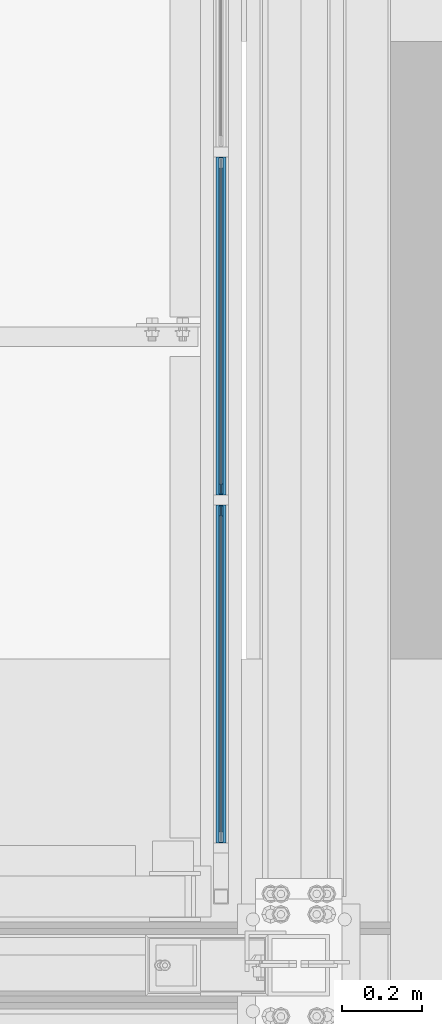
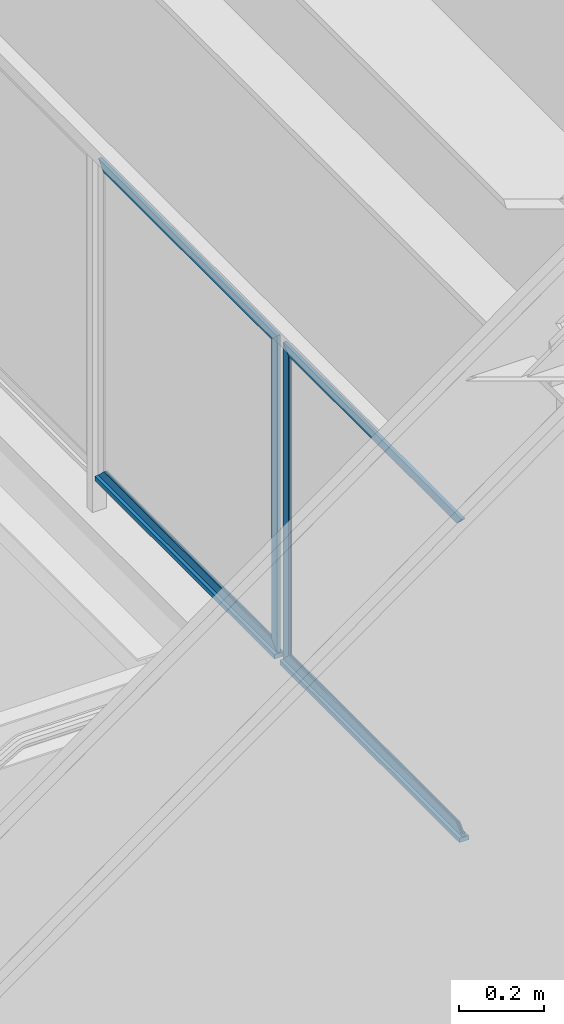
# One storey, part 924 of 1179: 6 beams, 2 members, 1 element without a shape of its own.
"""IFC2X3 building model written with IfcOpenShell, lengths in millimetres."""

from ifc_helpers import new_model, si_unit, frame, origin_with_axes, place, context, subcontext, project, spatial, faceted_brep, material, type_object, element, aggregate, save


model = new_model("IFC2X3")

# Units and contexts
model_context = context("Model", 3, precision=1e-05, world=origin_with_axes())
body_context = subcontext(model_context, "Body", "Model", "MODEL_VIEW")
ifc_project = project(units=[si_unit("LENGTHUNIT", "METRE", prefix="MILLI"), si_unit("AREAUNIT", "SQUARE_METRE"), si_unit("VOLUMEUNIT", "CUBIC_METRE"), si_unit("MASSUNIT", "GRAM", prefix="KILO"), si_unit("TIMEUNIT", "SECOND"), si_unit("PLANEANGLEUNIT", "RADIAN"), si_unit("SOLIDANGLEUNIT", "STERADIAN"), si_unit("THERMODYNAMICTEMPERATUREUNIT", "DEGREE_CELSIUS"), si_unit("LUMINOUSINTENSITYUNIT", "LUMEN")], contexts=[model_context])

# Site, building, storey
site_placement = place(None, origin_with_axes())
site = spatial("IfcSite", under=ifc_project, at=site_placement, CompositionType="ELEMENT")
building_placement = place(site_placement, origin_with_axes())
building = spatial("IfcBuilding", under=site, at=building_placement, Name="Undefined", CompositionType="ELEMENT")
storey_placement = place(building_placement, origin_with_axes())
storey = spatial("IfcBuildingStorey", under=building, at=storey_placement, Name="Undefined", CompositionType="ELEMENT", Elevation=0.0)

# Assembly, beams, members
assembly_placement = place(storey_placement, origin_with_axes())
assembly = element("IfcElementAssembly", 1, at=assembly_placement, inside=storey, Name="GUARDRAIL", AssemblyPlace="NOTDEFINED", PredefinedType="RIGID_FRAME")
ifc_material_1 = material(Name="STEEL/BUY-OUT")
beam_type = type_object("IfcBeamType", PredefinedType="NOTDEFINED")
beam_1_placement = place(assembly_placement, frame((24110.9500703529, 39183.3359575509, 2711.44999945388), z_axis=(0.0, 0.0, 1.0), x_axis=(0.0, -1.0, 0.0)))
beam_1 = element("IfcBeam", 2, at=beam_1_placement, type_object=beam_type, material=ifc_material_1, Name="U-EDGE", context=body_context, shape_type="Brep", body=[
    faceted_brep([(0.0, 1.58750000000146, -427.037571475466), (22.2249999999985, 1.58750000000146, -449.262071101228), (22.2249999999985, 4.76249999999709, -449.262071101228), (0.0, 4.76249999999709, -427.037571475466), (0.0, 7.9375, -427.037571475466), (25.4000000000015, 7.9375, -452.4375), (25.4000000000015, -1.58750000000146, -452.4375), (0.0, -1.58750000000146, -427.037571475466), (25.4000000000015, -1.58750000000146, 452.4375), (0.0, -1.58750000000146, 427.037500076054), (0.0, 1.58750000000146, 427.037500076054), (22.2249999999985, 1.58750000000146, 449.262500000033), (22.2249999999985, 4.76249999999709, 449.262500000033), (0.0, 4.76249999999709, 427.037500000033), (0.0, 7.9375, 427.037500000033), (25.4000000000015, 7.9375, 452.4375)], [[[0, 1, 2, 3, 4, 5, 6, 7]], [[7, 6, 8, 9]], [[0, 7, 9, 10]], [[1, 0, 10, 11]], [[2, 1, 11, 12]], [[3, 2, 12, 13]], [[4, 3, 13, 14]], [[5, 4, 14, 15]], [[6, 5, 15, 8]], [[14, 13, 12, 11, 10, 9, 8, 15]]]),
])
beam_2_placement = place(assembly_placement, frame((24110.9502052178, 39576.2424575509, 3138.48749945388), z_axis=(0.0, 1.0, 0.0), x_axis=(0.0, 0.0, 1.0)))
beam_2 = element("IfcBeam", 3, at=beam_2_placement, type_object=beam_type, material=ifc_material_1, Name="U-EDGE", context=body_context, shape_type="Brep", body=[
    faceted_brep([(0.0, 1.58750000000146, -392.906500000216), (22.2249999999785, 1.58750000000146, -415.131500000192), (22.2249999999603, 4.76236513509502, -415.131500000178), (-5.54791768081486e-11, 4.76236513509502, -392.906500000165), (-5.54791768081486e-11, 7.93736513509793, -392.906500000165), (25.3999999999414, 7.93736513509793, -418.306499999999), (25.3999999999969, -1.58750000000146, -418.306499999999), (0.0, -1.58750000000146, -392.906500000216), (25.3999999999969, -1.58750000000146, 418.306499999999), (0.0, -1.58750000000146, 392.90650078046), (0.0, 1.58750000000146, 392.90650078046), (22.2249999999785, 1.58750000000146, 415.131500780415), (22.2249999999603, 4.76236513509502, 415.131500780393), (-5.54791768081486e-11, 4.76236513509502, 392.90650078038), (-5.54791768081486e-11, 7.93736513509793, 392.90650078038), (25.3999999999414, 7.93736513509793, 418.306499999999)], [[[0, 1, 2, 3, 4, 5, 6, 7]], [[7, 6, 8, 9]], [[0, 7, 9, 10]], [[1, 0, 10, 11]], [[2, 1, 11, 12]], [[3, 2, 12, 13]], [[4, 3, 13, 14]], [[5, 4, 14, 15]], [[6, 5, 15, 8]], [[14, 13, 12, 11, 10, 9, 8, 15]]]),
])
beam_3_placement = place(assembly_placement, frame((24110.9502052178, 39576.2424575509, 2284.41249958167), z_axis=(0.0, 1.0, 0.0), x_axis=(0.0, 0.0, -1.0)))
beam_3 = element("IfcBeam", 4, at=beam_3_placement, type_object=beam_type, material=ifc_material_1, Name="U-EDGE", context=body_context, shape_type="Brep", body=[
    faceted_brep([(-5.45696821063757e-11, -4.76236513509502, -392.906500000157), (22.2249999999613, -4.76236513509502, -415.131500000178), (22.2249999999794, -1.58750000000146, -415.131500000192), (0.0, -1.58750000000146, -392.906500000216), (0.0, 1.58750000000146, -392.906500000216), (25.3999999999969, 1.58750000000146, -418.306499999999), (25.3999999999423, -7.93736513509793, -418.306499999999), (-5.45696821063757e-11, -7.93736513509793, -392.906500000157), (25.3999999999423, -7.93736513509793, 418.306499999999), (-5.45696821063757e-11, -7.93736513509793, 392.906500780409), (-5.45696821063757e-11, -4.76236513509502, 392.906500780409), (22.2249999999613, -4.76236513509502, 415.131500780422), (22.2249999999794, -1.58750000000146, 415.131500780437), (0.0, -1.58750000000146, 392.90650078046), (0.0, 1.58750000000146, 392.90650078046), (25.3999999999969, 1.58750000000146, 418.306499999999)], [[[0, 1, 2, 3, 4, 5, 6, 7]], [[7, 6, 8, 9]], [[0, 7, 9, 10]], [[1, 0, 10, 11]], [[2, 1, 11, 12]], [[3, 2, 12, 13]], [[4, 3, 13, 14]], [[5, 4, 14, 15]], [[6, 5, 15, 8]], [[14, 13, 12, 11, 10, 9, 8, 15]]]),
])
beam_4_placement = place(assembly_placement, frame((24110.9502052178, 38710.5257908844, 2284.41250006389), z_axis=(0.0, 1.0, 0.0), x_axis=(0.0, 0.0, -1.0)))
beam_4 = element("IfcBeam", 5, at=beam_4_placement, type_object=beam_type, material=ifc_material_1, Name="U-EDGE", context=body_context, shape_type="Brep", body=[
    faceted_brep([(-5.45696821063757e-11, -4.76236513509502, -392.906500000157), (22.2249999999613, -4.76236513509502, -415.131500000178), (22.2249999999794, -1.58750000000146, -415.131500000192), (0.0, -1.58750000000146, -392.906500000216), (0.0, 1.58750000000146, -392.906500000216), (25.3999999999969, 1.58750000000146, -418.306499999999), (25.3999999999423, -7.93736513509793, -418.306499999999), (-5.45696821063757e-11, -7.93736513509793, -392.906500000157), (25.3999999999423, -7.93736513509793, 418.306499999999), (-5.45696821063757e-11, -7.93736513509793, 392.906500780409), (-5.45696821063757e-11, -4.76236513509502, 392.906500780409), (22.2249999999613, -4.76236513509502, 415.131500780422), (22.2249999999794, -1.58750000000146, 415.131500780437), (0.0, -1.58750000000146, 392.90650078046), (0.0, 1.58750000000146, 392.90650078046), (25.3999999999969, 1.58750000000146, 418.306499999999)], [[[0, 1, 2, 3, 4, 5, 6, 7]], [[7, 6, 8, 9]], [[0, 7, 9, 10]], [[1, 0, 10, 11]], [[2, 1, 11, 12]], [[3, 2, 12, 13]], [[4, 3, 13, 14]], [[5, 4, 14, 15]], [[6, 5, 15, 8]], [[14, 13, 12, 11, 10, 9, 8, 15]]]),
])
beam_5_placement = place(assembly_placement, frame((24110.9500703529, 39103.4322916676, 2711.44999993605), z_axis=(0.0, 0.0, 1.0), x_axis=(0.0, 1.0, 0.0)))
beam_5 = element("IfcBeam", 6, at=beam_5_placement, type_object=beam_type, material=ifc_material_1, Name="U-EDGE", context=body_context, shape_type="Brep", body=[
    faceted_brep([(2.91038304567337e-11, -4.76249999999709, -427.037499923914), (22.2250000000131, -4.76249999999709, -449.2624999239), (22.2250000000131, -1.58750000000146, -449.2624999239), (0.0, -1.58750000000146, -427.037499923886), (0.0, 1.58750000000146, -427.037499923886), (25.4000000439901, 1.58750000000146, -452.437500000357), (25.4000000476099, -7.93749999539432, -452.437500000422), (2.91038304567337e-11, -7.9375, -427.037499923914), (25.4000000000647, -7.9375, 452.4375), (1.29148247651756e-10, -7.9375, 427.037500076181), (1.29148247651756e-10, -4.76249999999709, 427.037500076181), (22.2250000000645, -4.76249999999709, 449.262500076118), (22.2250000000645, -1.58750000000146, 449.262500076118), (0.0, -1.58750000000146, 427.037500076054), (0.0, 1.58750000000146, 427.037500076054), (25.4000000000647, 1.58750000000146, 452.4375)], [[[0, 1, 2, 3, 4, 5, 6, 7]], [[8, 9, 7, 6]], [[9, 10, 0, 7]], [[10, 11, 1, 0]], [[11, 12, 2, 1]], [[12, 13, 3, 2]], [[13, 14, 4, 3]], [[14, 15, 5, 4]], [[15, 8, 6, 5]], [[14, 13, 12, 11, 10, 9, 8, 15]]]),
])
beam_6_placement = place(assembly_placement, frame((24110.9502052178, 38710.5257908844, 3138.48749993611), z_axis=(0.0, 1.0, 0.0), x_axis=(0.0, 0.0, 1.0)))
beam_6 = element("IfcBeam", 7, at=beam_6_placement, type_object=beam_type, material=ifc_material_1, Name="U-EDGE", context=body_context, shape_type="Brep", body=[
    faceted_brep([(0.0, 1.58750000000146, -392.906500000216), (22.2249999999785, 1.58750000000146, -415.131500000192), (22.2249999999603, 4.76236513509502, -415.131500000178), (-5.54791768081486e-11, 4.76236513509502, -392.906500000165), (-5.54791768081486e-11, 7.93736513509793, -392.906500000165), (25.3999999999414, 7.93736513509793, -418.306499999999), (25.3999999999969, -1.58750000000146, -418.306499999999), (0.0, -1.58750000000146, -392.906500000216), (25.3999999999969, -1.58750000000146, 418.306499999999), (0.0, -1.58750000000146, 392.90650078046), (0.0, 1.58750000000146, 392.90650078046), (22.2249999999785, 1.58750000000146, 415.131500780415), (22.2249999999603, 4.76236513509502, 415.131500780393), (-5.54791768081486e-11, 4.76236513509502, 392.90650078038), (-5.54791768081486e-11, 7.93736513509793, 392.90650078038), (25.3999999999414, 7.93736513509793, 418.306499999999)], [[[0, 1, 2, 3, 4, 5, 6, 7]], [[7, 6, 8, 9]], [[0, 7, 9, 10]], [[1, 0, 10, 11]], [[2, 1, 11, 12]], [[3, 2, 12, 13]], [[4, 3, 13, 14]], [[5, 4, 14, 15]], [[6, 5, 15, 8]], [[14, 13, 12, 11, 10, 9, 8, 15]]]),
])
ifc_material_2 = material(Name="STEEL/A36")
member_type = type_object("IfcMemberType", PredefinedType="NOTDEFINED")
member_1_placement = place(assembly_placement, frame((24114.1250004143, 39143.5166666676, 2251.07500042314), z_axis=(1.0, 0.0, 0.0), x_axis=(0.0, 1.0, 0.0)))
member_1 = element("IfcMember", 8, at=member_1_placement, type_object=member_type, material=ifc_material_2, Name="BOTTOM_RAIL", context=body_context, shape_type="Brep", body=[
    faceted_brep([(12.6999999999971, 6.35000000000036, -12.7000000000007), (12.6999999999971, 6.35000000000036, 12.7000000000007), (853.01666666659, 6.35000000000036, 12.7000000000007), (853.01666666659, 6.35000000000036, -12.7000000000007), (12.6999999999971, -6.35000000000036, 12.7000000000007), (853.01666666659, -6.35000000000036, 12.7000000000007), (12.6999999999971, -6.35000000000036, -12.7000000000007), (853.01666666659, -6.35000000000036, -12.7000000000007)], [[[0, 1, 2, 3]], [[1, 4, 5, 2]], [[4, 6, 7, 5]], [[6, 0, 3, 7]], [[5, 7, 3, 2]], [[6, 4, 1, 0]]]),
])
member_2_placement = place(assembly_placement, frame((24114.1250004143, 38277.800000001, 2251.07500042314), z_axis=(1.0, 0.0, 0.0), x_axis=(0.0, 1.0, 0.0)))
member_2 = element("IfcMember", 9, at=member_2_placement, type_object=member_type, material=ifc_material_2, Name="BOTTOM_RAIL", context=body_context, shape_type="Brep", body=[
    faceted_brep([(12.6999999999971, 6.35000000000036, -12.7000000000007), (12.6999999999971, 6.35000000000036, 12.7000000000007), (853.01666666659, 6.35000000000036, 12.7000000000007), (853.01666666659, 6.35000000000036, -12.7000000000007), (12.6999999999971, -6.35000000000036, 12.7000000000007), (853.01666666659, -6.35000000000036, 12.7000000000007), (12.6999999999971, -6.35000000000036, -12.7000000000007), (853.01666666659, -6.35000000000036, -12.7000000000007)], [[[0, 1, 2, 3]], [[1, 4, 5, 2]], [[4, 6, 7, 5]], [[6, 0, 3, 7]], [[5, 7, 3, 2]], [[6, 4, 1, 0]]]),
])
aggregate(assembly, [beam_1, beam_2, beam_3, member_1, beam_4, beam_5, beam_6, member_2])

save(model, "model.ifc")
